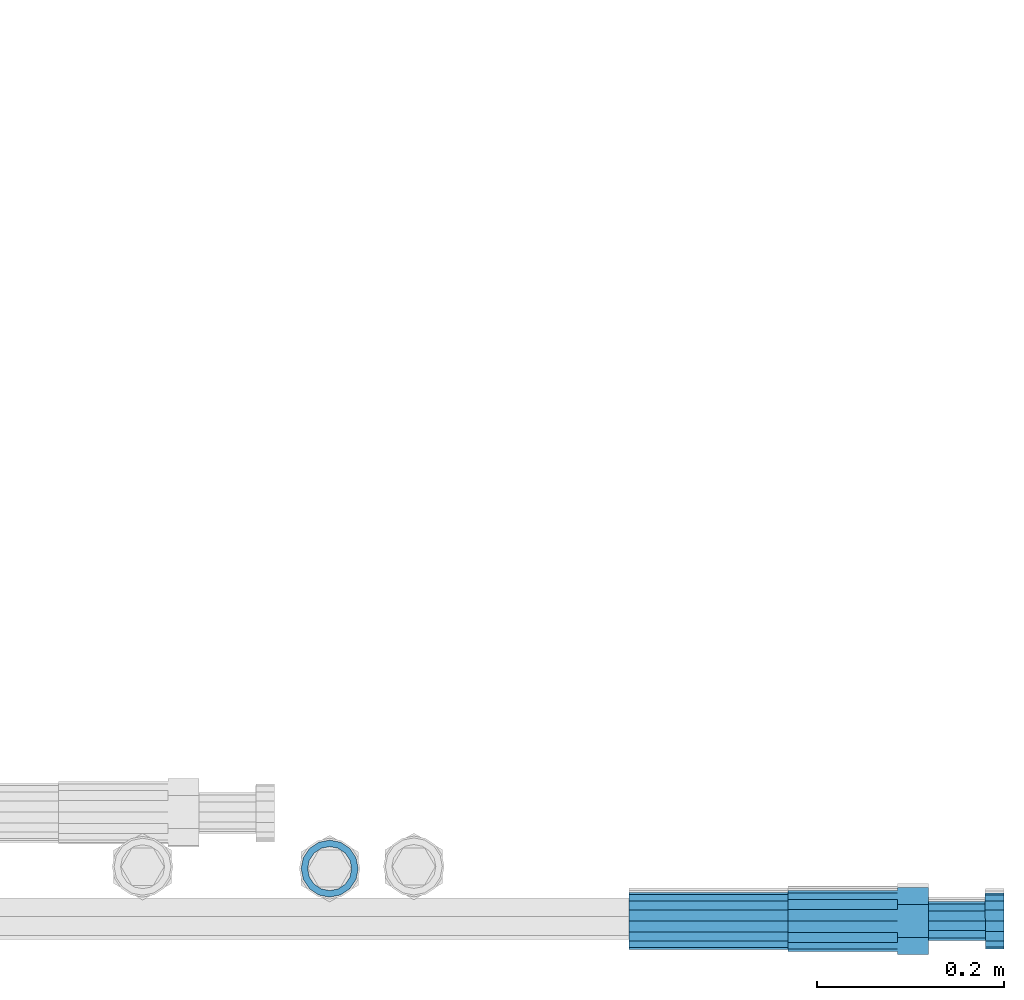
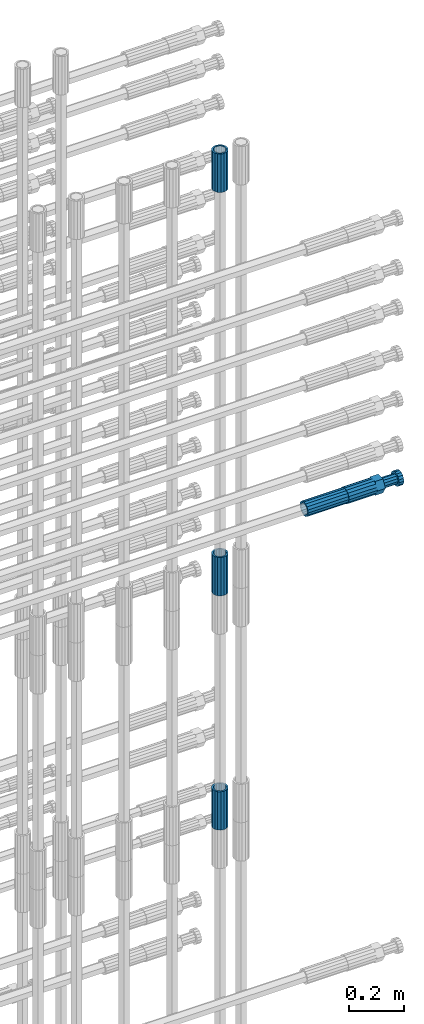
# One storey, part 104 of 119: 5 beams.
"""IFC2X3 building model written with IfcOpenShell, lengths in millimetres."""

from ifc_helpers import new_model, si_unit, frame, origin_with_axes, place, context, subcontext, project, spatial, faceted_brep, material, type_object, element, save


model = new_model("IFC2X3")

# Units and contexts
model_context = context("Model", 3, precision=1e-05, world=origin_with_axes())
body_context = subcontext(model_context, "Body", "Model", "MODEL_VIEW")
ifc_project = project(units=[si_unit("LENGTHUNIT", "METRE", prefix="MILLI"), si_unit("AREAUNIT", "SQUARE_METRE"), si_unit("VOLUMEUNIT", "CUBIC_METRE"), si_unit("MASSUNIT", "GRAM", prefix="KILO"), si_unit("TIMEUNIT", "SECOND"), si_unit("PLANEANGLEUNIT", "RADIAN"), si_unit("SOLIDANGLEUNIT", "STERADIAN"), si_unit("THERMODYNAMICTEMPERATUREUNIT", "DEGREE_CELSIUS"), si_unit("LUMINOUSINTENSITYUNIT", "LUMEN")], contexts=[model_context])

# Site, building, storey
site_placement = place(None, origin_with_axes())
site = spatial("IfcSite", under=ifc_project, at=site_placement, CompositionType="ELEMENT")
building_placement = place(site_placement, origin_with_axes())
building = spatial("IfcBuilding", under=site, at=building_placement, Name="Undefined", CompositionType="ELEMENT")
storey_placement = place(building_placement, origin_with_axes())
storey = spatial("IfcBuildingStorey", under=building, at=storey_placement, Name="Undefined", CompositionType="ELEMENT", Elevation=0.0)

# Beams
ifc_material = material(Name="STEEL/S275")
beam_type_1 = type_object("IfcBeamType", PredefinedType="NOTDEFINED")
beam_1_placement = place(storey_placement, frame((2039028.98112118, 6205154.42663665, 20007.7168583139), z_axis=(-0.99999999999998, 1.98000110685822e-07, 0.0), x_axis=(0.0, 0.0, -1.0)))
element("IfcBeam", 1, at=beam_1_placement, inside=storey, type_object=beam_type_1, material=ifc_material, Name="AG40N", context=body_context, shape_type="Brep", body=[
    faceted_brep([(1.62981450557709e-09, -23.4999999990687, 0.0), (7.45058059692383e-09, -21.7111690142192, 8.99306066057534), (170.000002125278, -21.711168999318, 8.99306066022245), (170.000002127141, -23.4999999844003, -3.66071617463604e-10), (4.65661287307739e-09, -16.6170093587134, 16.6170093578889), (170.000002122484, -16.6170093440451, 16.6170093575288), (1.86264514923096e-09, -8.99306066217832, 21.7111690140277), (170.000002118759, -8.99306064750999, 21.7111690136603), (2.3283064365387e-10, 9.31322574615479e-10, 23.5), (170.000002114102, 1.28056854009628e-08, 23.4999999996485), (-6.51925802230835e-09, 8.99306065868586, 21.7111690140241), (170.00000211224, 8.99306067335419, 21.7111690136639), (-7.45058059692383e-09, 16.6170093561523, 16.6170093578853), (170.000002109446, 16.6170093708206, 16.6170093575324), (-9.31322574615479e-09, 21.711169013055, 8.99306066057534), (170.000002108514, 21.7111690277234, 8.99306066022245), (-1.16415321826935e-09, 23.5000000009313, 0.0), (170.000002108514, 23.5000000144355, -3.66071617463604e-10), (-8.38190317153931e-09, 21.7111690151505, -8.99306066059444), (170.000002110377, 21.7111690300517, -8.9930606609546), (-5.58793544769287e-09, 16.6170093598776, -16.6170093579008), (170.000002113171, 16.6170093745459, -16.6170093582609), (-9.31322574615479e-10, 8.99306066334248, -21.7111690140396), (170.000002115965, 8.99306067801081, -21.7111690143961), (2.3283064365387e-10, 9.31322574615479e-10, -23.5), (170.00000211969, 1.7927959561348e-08, -23.5000000003843), (5.58793544769287e-09, -8.99306065752171, -21.7111690140396), (170.000002123415, -8.99306064285338, -21.7111690143961), (8.38190317153931e-09, -16.6170093549881, -16.6170093579008), (170.000002125278, -16.6170093403198, -16.6170093582646), (9.31322574615479e-09, -21.7111690121237, -8.99306066059444), (170.000002127141, -21.7111689972226, -8.9930606609546), (1.11758708953857e-08, -30.4999999990687, -9.54969436861575e-12), (1.30385160446167e-08, -28.1783257392235, -11.6718446871514), (170.000002129003, -28.1783257243223, -11.6718446875116), (170.000002129935, -30.4999999841675, -3.66071617463604e-10), (1.02445483207703e-08, -21.5667568228673, -21.5667568262129), (170.000002128072, -21.566756808199, -21.5667568265694), (7.45058059692383e-09, -11.6718446831219, -28.1783257416196), (170.000002125278, -11.6718446684536, -28.1783257419834), (3.72529029846191e-09, 3.95812094211578e-09, -30.5000000000277), (170.00000211969, 1.83936208486557e-08, -30.5000000003879), (-9.31322574615479e-10, 11.6718446905725, -28.1783257416232), (170.000002115965, 11.6718447052408, -28.1783257419797), (-6.51925802230835e-09, 21.5667568286881, -21.5667568262093), (170.000002110377, 21.5667568433564, -21.5667568265694), (-9.31322574615479e-09, 28.178325742716, -11.6718446871478), (170.000002108514, 28.1783257573843, -11.6718446875079), (-1.21071934700012e-08, 30.5, -5.91171556152403e-12), (170.000002106652, 30.5000000144355, -3.62433638656512e-10), (-1.21071934700012e-08, 28.1783257401548, 11.6718446871359), (170.00000210572, 28.1783257548232, 11.6718446867794), (-1.02445483207703e-08, 21.5667568240315, 21.5667568261974), (170.000002107583, 21.566756838467, 21.5667568258409), (-7.45058059692383e-09, 11.671844684286, 28.1783257416041), (170.000002110377, 11.6718446989544, 28.178325741244), (-2.79396772384644e-09, -2.56113708019257e-09, 30.5000000000159), (170.000002114102, 1.18743628263474e-08, 30.4999999996558), (1.86264514923096e-09, -11.6718446896411, 28.1783257416114), (170.000002118759, -11.67184467474, 28.178325741244), (7.45058059692383e-09, -21.5667568275239, 21.5667568261974), (170.000002123415, -21.5667568126228, 21.5667568258373), (1.02445483207703e-08, -28.1783257415518, 11.6718446871359), (170.000002127141, -28.1783257271163, 11.6718446867794)], [[[0, 1, 2, 3]], [[1, 4, 5, 2]], [[4, 6, 7, 5]], [[6, 8, 9, 7]], [[8, 10, 11, 9]], [[10, 12, 13, 11]], [[12, 14, 15, 13]], [[14, 16, 17, 15]], [[16, 18, 19, 17]], [[18, 20, 21, 19]], [[20, 22, 23, 21]], [[22, 24, 25, 23]], [[24, 26, 27, 25]], [[26, 28, 29, 27]], [[28, 30, 31, 29]], [[30, 0, 3, 31]], [[32, 33, 34, 35]], [[33, 36, 37, 34]], [[36, 38, 39, 37]], [[38, 40, 41, 39]], [[40, 42, 43, 41]], [[42, 44, 45, 43]], [[44, 46, 47, 45]], [[46, 48, 49, 47]], [[48, 50, 51, 49]], [[50, 52, 53, 51]], [[52, 54, 55, 53]], [[54, 56, 57, 55]], [[56, 58, 59, 57]], [[58, 60, 61, 59]], [[60, 62, 63, 61]], [[62, 32, 35, 63]], [[37, 39, 41, 43, 45, 47, 49, 51, 53, 55, 57, 59, 61, 63, 35, 34], [5, 7, 9, 11, 13, 15, 17, 19, 21, 23, 25, 27, 29, 31, 3, 2]], [[62, 60, 58, 56, 54, 52, 50, 48, 46, 44, 42, 40, 38, 36, 33, 32], [30, 28, 26, 24, 22, 20, 18, 16, 14, 12, 10, 8, 6, 4, 1, 0]]]),
])
beam_2_placement = place(storey_placement, frame((2039028.98112118, 6205154.42663664, 22659.985729163), z_axis=(1.0, 0.0, 0.0), x_axis=(0.0, 0.0, 1.0)))
element("IfcBeam", 2, at=beam_2_placement, inside=storey, type_object=beam_type_1, material=ifc_material, Name="AG40N", context=body_context, shape_type="Brep", body=[
    faceted_brep([(1.62981450557709e-09, -23.4999999990687, 0.0), (7.45058059692383e-09, -21.7111690142192, 8.99306066057534), (170.000002125278, -21.711168999318, 8.99306066022245), (170.000002127141, -23.4999999844003, -3.66071617463604e-10), (4.65661287307739e-09, -16.6170093587134, 16.6170093578889), (170.000002122484, -16.6170093440451, 16.6170093575288), (1.86264514923096e-09, -8.99306066217832, 21.7111690140277), (170.000002118759, -8.99306064750999, 21.7111690136603), (2.3283064365387e-10, 9.31322574615479e-10, 23.5), (170.000002114102, 1.28056854009628e-08, 23.4999999996485), (-6.51925802230835e-09, 8.99306065868586, 21.7111690140241), (170.00000211224, 8.99306067335419, 21.7111690136639), (-7.45058059692383e-09, 16.6170093561523, 16.6170093578853), (170.000002109446, 16.6170093708206, 16.6170093575324), (-9.31322574615479e-09, 21.711169013055, 8.99306066057534), (170.000002108514, 21.7111690277234, 8.99306066022245), (-1.16415321826935e-09, 23.5000000009313, 0.0), (170.000002108514, 23.5000000144355, -3.66071617463604e-10), (-8.38190317153931e-09, 21.7111690151505, -8.99306066059444), (170.000002110377, 21.7111690300517, -8.9930606609546), (-5.58793544769287e-09, 16.6170093598776, -16.6170093579008), (170.000002113171, 16.6170093745459, -16.6170093582609), (-9.31322574615479e-10, 8.99306066334248, -21.7111690140396), (170.000002115965, 8.99306067801081, -21.7111690143961), (2.3283064365387e-10, 9.31322574615479e-10, -23.5), (170.00000211969, 1.7927959561348e-08, -23.5000000003843), (5.58793544769287e-09, -8.99306065752171, -21.7111690140396), (170.000002123415, -8.99306064285338, -21.7111690143961), (8.38190317153931e-09, -16.6170093549881, -16.6170093579008), (170.000002125278, -16.6170093403198, -16.6170093582646), (9.31322574615479e-09, -21.7111690121237, -8.99306066059444), (170.000002127141, -21.7111689972226, -8.9930606609546), (1.11758708953857e-08, -30.4999999990687, -9.54969436861575e-12), (1.30385160446167e-08, -28.1783257392235, -11.6718446871514), (170.000002129003, -28.1783257243223, -11.6718446875116), (170.000002129935, -30.4999999841675, -3.66071617463604e-10), (1.02445483207703e-08, -21.5667568228673, -21.5667568262129), (170.000002128072, -21.566756808199, -21.5667568265694), (7.45058059692383e-09, -11.6718446831219, -28.1783257416196), (170.000002125278, -11.6718446684536, -28.1783257419834), (3.72529029846191e-09, 3.95812094211578e-09, -30.5000000000277), (170.00000211969, 1.83936208486557e-08, -30.5000000003879), (-9.31322574615479e-10, 11.6718446905725, -28.1783257416232), (170.000002115965, 11.6718447052408, -28.1783257419797), (-6.51925802230835e-09, 21.5667568286881, -21.5667568262093), (170.000002110377, 21.5667568433564, -21.5667568265694), (-9.31322574615479e-09, 28.178325742716, -11.6718446871478), (170.000002108514, 28.1783257573843, -11.6718446875079), (-1.21071934700012e-08, 30.5, -5.91171556152403e-12), (170.000002106652, 30.5000000144355, -3.62433638656512e-10), (-1.21071934700012e-08, 28.1783257401548, 11.6718446871359), (170.00000210572, 28.1783257548232, 11.6718446867794), (-1.02445483207703e-08, 21.5667568240315, 21.5667568261974), (170.000002107583, 21.566756838467, 21.5667568258409), (-7.45058059692383e-09, 11.671844684286, 28.1783257416041), (170.000002110377, 11.6718446989544, 28.178325741244), (-2.79396772384644e-09, -2.56113708019257e-09, 30.5000000000159), (170.000002114102, 1.18743628263474e-08, 30.4999999996558), (1.86264514923096e-09, -11.6718446896411, 28.1783257416114), (170.000002118759, -11.67184467474, 28.178325741244), (7.45058059692383e-09, -21.5667568275239, 21.5667568261974), (170.000002123415, -21.5667568126228, 21.5667568258373), (1.02445483207703e-08, -28.1783257415518, 11.6718446871359), (170.000002127141, -28.1783257271163, 11.6718446867794)], [[[0, 1, 2, 3]], [[1, 4, 5, 2]], [[4, 6, 7, 5]], [[6, 8, 9, 7]], [[8, 10, 11, 9]], [[10, 12, 13, 11]], [[12, 14, 15, 13]], [[14, 16, 17, 15]], [[16, 18, 19, 17]], [[18, 20, 21, 19]], [[20, 22, 23, 21]], [[22, 24, 25, 23]], [[24, 26, 27, 25]], [[26, 28, 29, 27]], [[28, 30, 31, 29]], [[30, 0, 3, 31]], [[32, 33, 34, 35]], [[33, 36, 37, 34]], [[36, 38, 39, 37]], [[38, 40, 41, 39]], [[40, 42, 43, 41]], [[42, 44, 45, 43]], [[44, 46, 47, 45]], [[46, 48, 49, 47]], [[48, 50, 51, 49]], [[50, 52, 53, 51]], [[52, 54, 55, 53]], [[54, 56, 57, 55]], [[56, 58, 59, 57]], [[58, 60, 61, 59]], [[60, 62, 63, 61]], [[62, 32, 35, 63]], [[37, 39, 41, 43, 45, 47, 49, 51, 53, 55, 57, 59, 61, 63, 35, 34], [5, 7, 9, 11, 13, 15, 17, 19, 21, 23, 25, 27, 29, 31, 3, 2]], [[62, 60, 58, 56, 54, 52, 50, 48, 46, 44, 42, 40, 38, 36, 33, 32], [30, 28, 26, 24, 22, 20, 18, 16, 14, 12, 10, 8, 6, 4, 1, 0]]]),
])
beam_3_placement = place(storey_placement, frame((2039028.98112118, 6205154.42663665, 21044.6068583132), z_axis=(-0.99999999999998, 1.98000110685822e-07, 0.0), x_axis=(0.0, 0.0, -1.0)))
element("IfcBeam", 3, at=beam_3_placement, inside=storey, type_object=beam_type_1, material=ifc_material, Name="AG40N", context=body_context, shape_type="Brep", body=[
    faceted_brep([(1.62981450557709e-09, -23.4999999990687, 0.0), (7.45058059692383e-09, -21.7111690142192, 8.99306066057534), (170.000002125278, -21.711168999318, 8.99306066022245), (170.000002127141, -23.4999999844003, -3.66071617463604e-10), (4.65661287307739e-09, -16.6170093587134, 16.6170093578889), (170.000002122484, -16.6170093440451, 16.6170093575288), (1.86264514923096e-09, -8.99306066217832, 21.7111690140277), (170.000002118759, -8.99306064750999, 21.7111690136603), (2.3283064365387e-10, 9.31322574615479e-10, 23.5), (170.000002114102, 1.28056854009628e-08, 23.4999999996485), (-6.51925802230835e-09, 8.99306065868586, 21.7111690140241), (170.00000211224, 8.99306067335419, 21.7111690136639), (-7.45058059692383e-09, 16.6170093561523, 16.6170093578853), (170.000002109446, 16.6170093708206, 16.6170093575324), (-9.31322574615479e-09, 21.711169013055, 8.99306066057534), (170.000002108514, 21.7111690277234, 8.99306066022245), (-1.16415321826935e-09, 23.5000000009313, 0.0), (170.000002108514, 23.5000000144355, -3.66071617463604e-10), (-8.38190317153931e-09, 21.7111690151505, -8.99306066059444), (170.000002110377, 21.7111690300517, -8.9930606609546), (-5.58793544769287e-09, 16.6170093598776, -16.6170093579008), (170.000002113171, 16.6170093745459, -16.6170093582609), (-9.31322574615479e-10, 8.99306066334248, -21.7111690140396), (170.000002115965, 8.99306067801081, -21.7111690143961), (2.3283064365387e-10, 9.31322574615479e-10, -23.5), (170.00000211969, 1.7927959561348e-08, -23.5000000003843), (5.58793544769287e-09, -8.99306065752171, -21.7111690140396), (170.000002123415, -8.99306064285338, -21.7111690143961), (8.38190317153931e-09, -16.6170093549881, -16.6170093579008), (170.000002125278, -16.6170093403198, -16.6170093582646), (9.31322574615479e-09, -21.7111690121237, -8.99306066059444), (170.000002127141, -21.7111689972226, -8.9930606609546), (1.11758708953857e-08, -30.4999999990687, -9.54969436861575e-12), (1.30385160446167e-08, -28.1783257392235, -11.6718446871514), (170.000002129003, -28.1783257243223, -11.6718446875116), (170.000002129935, -30.4999999841675, -3.66071617463604e-10), (1.02445483207703e-08, -21.5667568228673, -21.5667568262129), (170.000002128072, -21.566756808199, -21.5667568265694), (7.45058059692383e-09, -11.6718446831219, -28.1783257416196), (170.000002125278, -11.6718446684536, -28.1783257419834), (3.72529029846191e-09, 3.95812094211578e-09, -30.5000000000277), (170.00000211969, 1.83936208486557e-08, -30.5000000003879), (-9.31322574615479e-10, 11.6718446905725, -28.1783257416232), (170.000002115965, 11.6718447052408, -28.1783257419797), (-6.51925802230835e-09, 21.5667568286881, -21.5667568262093), (170.000002110377, 21.5667568433564, -21.5667568265694), (-9.31322574615479e-09, 28.178325742716, -11.6718446871478), (170.000002108514, 28.1783257573843, -11.6718446875079), (-1.21071934700012e-08, 30.5, -5.91171556152403e-12), (170.000002106652, 30.5000000144355, -3.62433638656512e-10), (-1.21071934700012e-08, 28.1783257401548, 11.6718446871359), (170.00000210572, 28.1783257548232, 11.6718446867794), (-1.02445483207703e-08, 21.5667568240315, 21.5667568261974), (170.000002107583, 21.566756838467, 21.5667568258409), (-7.45058059692383e-09, 11.671844684286, 28.1783257416041), (170.000002110377, 11.6718446989544, 28.178325741244), (-2.79396772384644e-09, -2.56113708019257e-09, 30.5000000000159), (170.000002114102, 1.18743628263474e-08, 30.4999999996558), (1.86264514923096e-09, -11.6718446896411, 28.1783257416114), (170.000002118759, -11.67184467474, 28.178325741244), (7.45058059692383e-09, -21.5667568275239, 21.5667568261974), (170.000002123415, -21.5667568126228, 21.5667568258373), (1.02445483207703e-08, -28.1783257415518, 11.6718446871359), (170.000002127141, -28.1783257271163, 11.6718446867794)], [[[0, 1, 2, 3]], [[1, 4, 5, 2]], [[4, 6, 7, 5]], [[6, 8, 9, 7]], [[8, 10, 11, 9]], [[10, 12, 13, 11]], [[12, 14, 15, 13]], [[14, 16, 17, 15]], [[16, 18, 19, 17]], [[18, 20, 21, 19]], [[20, 22, 23, 21]], [[22, 24, 25, 23]], [[24, 26, 27, 25]], [[26, 28, 29, 27]], [[28, 30, 31, 29]], [[30, 0, 3, 31]], [[32, 33, 34, 35]], [[33, 36, 37, 34]], [[36, 38, 39, 37]], [[38, 40, 41, 39]], [[40, 42, 43, 41]], [[42, 44, 45, 43]], [[44, 46, 47, 45]], [[46, 48, 49, 47]], [[48, 50, 51, 49]], [[50, 52, 53, 51]], [[52, 54, 55, 53]], [[54, 56, 57, 55]], [[56, 58, 59, 57]], [[58, 60, 61, 59]], [[60, 62, 63, 61]], [[62, 32, 35, 63]], [[37, 39, 41, 43, 45, 47, 49, 51, 53, 55, 57, 59, 61, 63, 35, 34], [5, 7, 9, 11, 13, 15, 17, 19, 21, 23, 25, 27, 29, 31, 3, 2]], [[62, 60, 58, 56, 54, 52, 50, 48, 46, 44, 42, 40, 38, 36, 33, 32], [30, 28, 26, 24, 22, 20, 18, 16, 14, 12, 10, 8, 6, 4, 1, 0]]]),
])
beam_4_placement = place(storey_placement, frame((2039349.03023304, 6205098.48994599, 21160.9894122944), z_axis=(0.0, 0.0, 1.0), x_axis=(1.0, 0.0, 0.0)))
element("IfcBeam", 4, at=beam_4_placement, inside=storey, type_object=beam_type_1, material=ifc_material, Name="AG40N", context=body_context, shape_type="Brep", body=[
    faceted_brep([(1.62981450557709e-09, -23.4999999990687, 0.0), (7.45058059692383e-09, -21.7111690142192, 8.99306066057534), (170.000002125278, -21.711168999318, 8.99306066022245), (170.000002127141, -23.4999999844003, -3.66071617463604e-10), (4.65661287307739e-09, -16.6170093587134, 16.6170093578889), (170.000002122484, -16.6170093440451, 16.6170093575288), (1.86264514923096e-09, -8.99306066217832, 21.7111690140277), (170.000002118759, -8.99306064750999, 21.7111690136603), (2.3283064365387e-10, 9.31322574615479e-10, 23.5), (170.000002114102, 1.28056854009628e-08, 23.4999999996485), (-6.51925802230835e-09, 8.99306065868586, 21.7111690140241), (170.00000211224, 8.99306067335419, 21.7111690136639), (-7.45058059692383e-09, 16.6170093561523, 16.6170093578853), (170.000002109446, 16.6170093708206, 16.6170093575324), (-9.31322574615479e-09, 21.711169013055, 8.99306066057534), (170.000002108514, 21.7111690277234, 8.99306066022245), (-1.16415321826935e-09, 23.5000000009313, 0.0), (170.000002108514, 23.5000000144355, -3.66071617463604e-10), (-8.38190317153931e-09, 21.7111690151505, -8.99306066059444), (170.000002110377, 21.7111690300517, -8.9930606609546), (-5.58793544769287e-09, 16.6170093598776, -16.6170093579008), (170.000002113171, 16.6170093745459, -16.6170093582609), (-9.31322574615479e-10, 8.99306066334248, -21.7111690140396), (170.000002115965, 8.99306067801081, -21.7111690143961), (2.3283064365387e-10, 9.31322574615479e-10, -23.5), (170.00000211969, 1.7927959561348e-08, -23.5000000003843), (5.58793544769287e-09, -8.99306065752171, -21.7111690140396), (170.000002123415, -8.99306064285338, -21.7111690143961), (8.38190317153931e-09, -16.6170093549881, -16.6170093579008), (170.000002125278, -16.6170093403198, -16.6170093582646), (9.31322574615479e-09, -21.7111690121237, -8.99306066059444), (170.000002127141, -21.7111689972226, -8.9930606609546), (1.11758708953857e-08, -30.4999999990687, -9.54969436861575e-12), (1.30385160446167e-08, -28.1783257392235, -11.6718446871514), (170.000002129003, -28.1783257243223, -11.6718446875116), (170.000002129935, -30.4999999841675, -3.66071617463604e-10), (1.02445483207703e-08, -21.5667568228673, -21.5667568262129), (170.000002128072, -21.566756808199, -21.5667568265694), (7.45058059692383e-09, -11.6718446831219, -28.1783257416196), (170.000002125278, -11.6718446684536, -28.1783257419834), (3.72529029846191e-09, 3.95812094211578e-09, -30.5000000000277), (170.00000211969, 1.83936208486557e-08, -30.5000000003879), (-9.31322574615479e-10, 11.6718446905725, -28.1783257416232), (170.000002115965, 11.6718447052408, -28.1783257419797), (-6.51925802230835e-09, 21.5667568286881, -21.5667568262093), (170.000002110377, 21.5667568433564, -21.5667568265694), (-9.31322574615479e-09, 28.178325742716, -11.6718446871478), (170.000002108514, 28.1783257573843, -11.6718446875079), (-1.21071934700012e-08, 30.5, -5.91171556152403e-12), (170.000002106652, 30.5000000144355, -3.62433638656512e-10), (-1.21071934700012e-08, 28.1783257401548, 11.6718446871359), (170.00000210572, 28.1783257548232, 11.6718446867794), (-1.02445483207703e-08, 21.5667568240315, 21.5667568261974), (170.000002107583, 21.566756838467, 21.5667568258409), (-7.45058059692383e-09, 11.671844684286, 28.1783257416041), (170.000002110377, 11.6718446989544, 28.178325741244), (-2.79396772384644e-09, -2.56113708019257e-09, 30.5000000000159), (170.000002114102, 1.18743628263474e-08, 30.4999999996558), (1.86264514923096e-09, -11.6718446896411, 28.1783257416114), (170.000002118759, -11.67184467474, 28.178325741244), (7.45058059692383e-09, -21.5667568275239, 21.5667568261974), (170.000002123415, -21.5667568126228, 21.5667568258373), (1.02445483207703e-08, -28.1783257415518, 11.6718446871359), (170.000002127141, -28.1783257271163, 11.6718446867794)], [[[0, 1, 2, 3]], [[1, 4, 5, 2]], [[4, 6, 7, 5]], [[6, 8, 9, 7]], [[8, 10, 11, 9]], [[10, 12, 13, 11]], [[12, 14, 15, 13]], [[14, 16, 17, 15]], [[16, 18, 19, 17]], [[18, 20, 21, 19]], [[20, 22, 23, 21]], [[22, 24, 25, 23]], [[24, 26, 27, 25]], [[26, 28, 29, 27]], [[28, 30, 31, 29]], [[30, 0, 3, 31]], [[32, 33, 34, 35]], [[33, 36, 37, 34]], [[36, 38, 39, 37]], [[38, 40, 41, 39]], [[40, 42, 43, 41]], [[42, 44, 45, 43]], [[44, 46, 47, 45]], [[46, 48, 49, 47]], [[48, 50, 51, 49]], [[50, 52, 53, 51]], [[52, 54, 55, 53]], [[54, 56, 57, 55]], [[56, 58, 59, 57]], [[58, 60, 61, 59]], [[60, 62, 63, 61]], [[62, 32, 35, 63]], [[37, 39, 41, 43, 45, 47, 49, 51, 53, 55, 57, 59, 61, 63, 35, 34], [5, 7, 9, 11, 13, 15, 17, 19, 21, 23, 25, 27, 29, 31, 3, 2]], [[62, 60, 58, 56, 54, 52, 50, 48, 46, 44, 42, 40, 38, 36, 33, 32], [30, 28, 26, 24, 22, 20, 18, 16, 14, 12, 10, 8, 6, 4, 1, 0]]]),
])
beam_type_2 = type_object("IfcBeamType", Name="ROD65", PredefinedType="NOTDEFINED")
beam_5_placement = place(storey_placement, frame((2039519.03023304, 6205098.48994599, 21160.9894143809), z_axis=(0.0, 0.0, 1.0), x_axis=(1.0, 0.0, 0.0)))
element("IfcBeam", 5, at=beam_5_placement, inside=storey, type_object=beam_type_2, material=ifc_material, Name="AGB40", ObjectType="ROD65", context=body_context, shape_type="Brep", body=[
    faceted_brep([(116.999999999069, 17.8249999252148, 30.8738056446964), (116.999999998137, 22.0056957420893, 23.632628078838), (116.999999999069, 12.4372115600854, 30.0260848066173), (116.999999999069, 8.17543111252598, 30.8738056446964), (117.000000000931, -17.8250000746921, 30.8738056446964), (150.200000001118, -17.8250000723638, 30.8738056446964), (150.199999999255, 17.8249999275431, 30.8738056446964), (117.000000000931, -8.17543109622784, 30.8738056446964), (117.000000001863, -22.0056959956419, 23.6326278985034), (117.000000000931, -12.4372115437873, 30.0260848066173), (117.000000001863, -35.6500000746455, -2.18278728425503e-10), (150.200000002049, -35.6500000723172, -2.18278728425503e-10), (117.000000001863, -30.8443149488885, 8.32369080289209), (117.000000001863, -30.8443149488885, -8.32369080355784), (117.000000002794, -32.4999999918509, 0.0), (117.000000000931, -17.8250000746921, -30.873805645133), (150.200000001118, -17.8250000723638, -30.873805645133), (117.000000001863, -22.0056959961075, -23.6326278982269), (117.000000000931, -8.17543109389953, -30.873805645133), (117.000000000931, -12.4372115437873, -30.0260848066173), (116.999999999069, 17.8249999252148, -30.873805645133), (150.199999999255, 17.8249999275431, -30.873805645133), (116.999999999069, 8.17543111019768, -30.873805645133), (116.999999999069, 12.4372115600854, -30.0260848066173), (116.999999998137, 22.005695742555, -23.6326280785652), (116.999999998137, 35.6499999251682, -2.18278728425503e-10), (150.199999998324, 35.6499999277294, -2.18278728425503e-10), (116.999999998137, 30.8443150522653, -8.32369036550881), (116.999999997206, 32.5000000081491, 0.0), (116.999999998137, 30.8443150522653, 8.32369036483942), (1.86264514923096e-09, -22.9809703885112, 22.9809703885621), (1.86264514923096e-09, -30.0260848065373, 12.4372115518672), (117.000000001863, -30.0260847983882, 12.4372115518672), (117.000000001863, -22.9809703803621, 22.9809703885621), (-1.86264514923096e-09, 22.9809703885112, -22.9809703885621), (-1.86264514923096e-09, 30.0260848065373, -12.4372115518672), (116.999999998137, 30.0260848146863, -12.4372115518672), (116.999999998137, 22.9809703966603, -22.9809703885621), (1.86264514923096e-09, -30.0260848065373, -12.4372115518672), (1.86264514923096e-09, -22.9809703885112, -22.9809703885621), (117.000000001863, -22.9809703803621, -22.9809703885621), (117.000000001863, -30.0260847983882, -12.4372115518672), (9.31322574615479e-10, -12.4372115519363, 30.0260848066173), (0.0, 0.0, 32.5), (-9.31322574615479e-10, 12.4372115519363, 30.0260848066173), (-1.86264514923096e-09, 22.9809703885112, 22.9809703885621), (-1.86264514923096e-09, 30.0260848065373, 12.4372115518672), (-2.79396772384644e-09, 32.5, 0.0), (-9.31322574615479e-10, 12.4372115519363, -30.0260848066173), (0.0, 0.0, -32.5), (9.31322574615479e-10, -12.4372115519363, -30.0260848066173), (2.79396772384644e-09, -32.5, 0.0), (116.999999998137, 22.9809703966603, 22.9809703885621), (116.999999998137, 30.0260848146863, 12.4372115518672), (117.0, 8.14907252788544e-09, -32.5), (117.0, 8.14907252788544e-09, 32.5), (150.200000000186, -10.5000000959262, 18.1865334791873), (150.199999999255, -9.59262251853943e-08, 20.9999999997126), (150.199999998324, 10.4999999040738, 18.1865334791873), (150.199999997392, 18.1865333835594, 10.4999999997126), (150.199999997392, 20.9999999040738, -2.87400325760245e-10), (150.199999997392, 18.1865333835594, -10.5000000002874), (150.199999998324, 10.4999999040738, -18.1865334797621), (150.199999999255, -9.59262251853943e-08, -21.0000000002874), (150.200000000186, -10.5000000959262, -18.1865334797621), (150.200000000186, -18.1865335754119, -10.5000000002874), (150.200000001118, -21.0000000959262, -2.87400325760245e-10), (150.200000000186, -18.1865335754119, 10.4999999997126), (210.979999999516, 10.4999999082647, 18.1865334791873), (210.979999999516, -9.17352735996246e-08, 20.9999999997126), (210.979999997653, 18.1865333877504, 10.4999999997126), (210.979999997653, 20.9999999082647, -2.87400325760245e-10), (210.979999997653, 18.1865333877504, -10.5000000002874), (210.979999999516, 10.4999999082647, -18.1865334797621), (210.979999999516, -9.17352735996246e-08, -21.0000000002874), (210.979999999516, -10.5000000917353, -18.1865334797621), (210.980000000447, -18.1865335712209, -10.5000000002874), (210.980000001378, -21.0000000917353, -2.87400325760245e-10), (210.980000000447, -18.1865335712209, 10.4999999997126), (210.979999999516, -10.5000000917353, 18.1865334791873), (211.001368402503, -27.7269939335529, -11.4911163272045), (211.003082515672, -21.2238095656503, -21.2238154190527), (231.002518340945, -21.2131946226582, -21.2132004554769), (231.000804228708, -27.7163789905608, -11.4805013636287), (211.001368415542, -11.4911086384673, -27.7269970399575), (231.000804241747, -11.4804936954752, -27.7163820763781), (210.996487061493, -0.0106066407170147, -30.0106107396168), (230.995922887698, 8.30227509140968e-06, -29.999995776041), (210.98918159306, 11.4698940692469, -27.7269970332745), (230.988617419265, 11.4805090120062, -27.7163820696951), (210.980564201251, 21.2025913291145, -21.2238154067054), (230.980000027455, 21.2132062721066, -21.2132004431296), (210.971946807578, 27.7057702087332, -11.4911163110701), (230.971382633783, 27.7163851517253, -11.4805013474943), (210.964641331695, 29.9893806746695, -0.0106149565435771), (230.9640771579, 29.9999956176616, 7.03221303410828e-09), (210.959759964608, 27.7057637346443, 11.4698863966551), (230.959195790812, 27.7163786776364, 11.4805013602345), (210.958045851439, 21.2025793667417, 21.2025854885032), (230.957481677644, 21.2131943097338, 21.2132004520827), (210.959759951569, 11.4698784395587, 27.705767109408), (230.959195776843, 11.4804933823179, 27.7163820729838), (210.964641305618, -0.0106235581915826, 29.9893808090674), (230.964077131823, -8.61519947648048e-06, 29.9999957726432), (210.971946774051, -11.4911242681555, 27.7057671027251), (230.971382599324, -11.4805093251634, 27.7163820663009), (210.98056416586, -21.2238215280231, 21.2025854761559), (230.979999991134, -21.2132065852638, 21.2132004397354), (210.989181559533, -27.7270004076418, 11.4698863805206), (230.988617384806, -27.7163854646496, 11.4805013441), (210.996487035416, -30.0106108735781, -0.0106149740058754), (230.995922861621, -29.999995930586, -1.04300852399319e-08)], [[[0, 1, 2, 3]], [[4, 5, 6, 0, 3, 7]], [[8, 4, 7, 9]], [[10, 11, 5, 4, 8, 12]], [[13, 10, 12, 14]], [[15, 16, 11, 10, 13, 17]], [[18, 15, 17, 19]], [[20, 21, 16, 15, 18, 22]], [[20, 22, 23, 24]], [[25, 26, 21, 20, 24, 27]], [[25, 27, 28, 29]], [[30, 31, 32, 33]], [[34, 35, 36, 37]], [[38, 39, 40, 41]], [[31, 30, 42, 43, 44, 45, 46, 47, 35, 34, 48, 49, 50, 39, 38, 51]], [[46, 45, 52, 53]], [[28, 47, 46, 53, 29]], [[27, 36, 35, 47, 28]], [[24, 37, 36, 27]], [[23, 48, 34, 37, 24]], [[22, 54, 49, 48, 23]], [[18, 54, 22]], [[19, 50, 49, 54, 18]], [[17, 40, 39, 50, 19]], [[13, 41, 40, 17]], [[14, 51, 38, 41, 13]], [[12, 32, 31, 51, 14]], [[8, 33, 32, 12]], [[9, 42, 30, 33, 8]], [[7, 55, 43, 42, 9]], [[3, 55, 7]], [[2, 44, 43, 55, 3]], [[1, 52, 45, 44, 2]], [[29, 53, 52, 1]], [[0, 6, 26, 25, 29, 1]], [[5, 11, 16, 21, 26, 6], [56, 57, 58, 59, 60, 61, 62, 63, 64, 65, 66, 67]], [[68, 58, 57, 69]], [[70, 59, 58, 68]], [[71, 60, 59, 70]], [[72, 61, 60, 71]], [[73, 62, 61, 72]], [[74, 63, 62, 73]], [[75, 64, 63, 74]], [[76, 65, 64, 75]], [[77, 66, 65, 76]], [[78, 67, 66, 77]], [[79, 56, 67, 78]], [[69, 57, 56, 79]], [[80, 81, 82, 83]], [[81, 84, 85, 82]], [[84, 86, 87, 85]], [[86, 88, 89, 87]], [[88, 90, 91, 89]], [[90, 92, 93, 91]], [[92, 94, 95, 93]], [[94, 96, 97, 95]], [[96, 98, 99, 97]], [[98, 100, 101, 99]], [[100, 102, 103, 101]], [[102, 104, 105, 103]], [[104, 106, 107, 105]], [[106, 108, 109, 107]], [[108, 110, 111, 109]], [[82, 85, 87, 89, 91, 93, 95, 97, 99, 101, 103, 105, 107, 109, 111, 83]], [[110, 80, 83, 111]], [[108, 106, 104, 102, 100, 98, 96, 94, 92, 90, 88, 86, 84, 81, 80, 110], [78, 77, 76, 75, 74, 73, 72, 71, 70, 68, 69, 79]]]),
])

save(model, "model.ifc")
